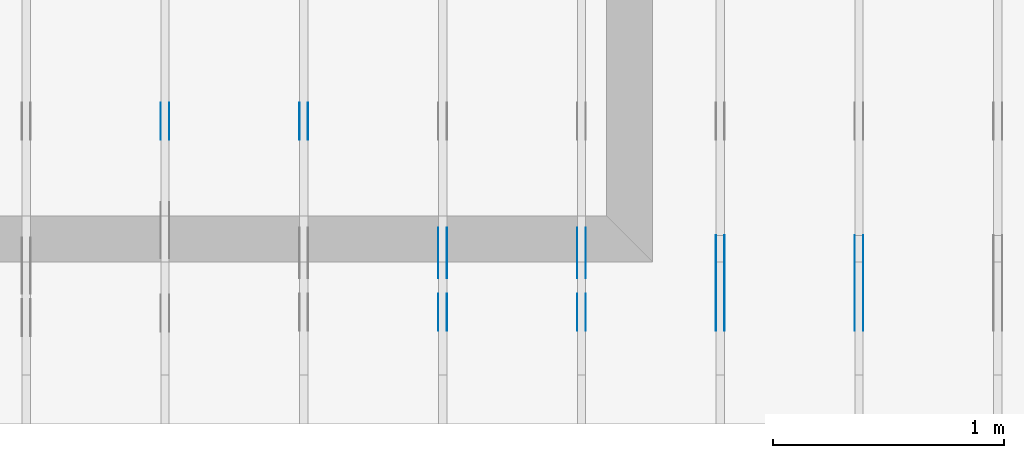
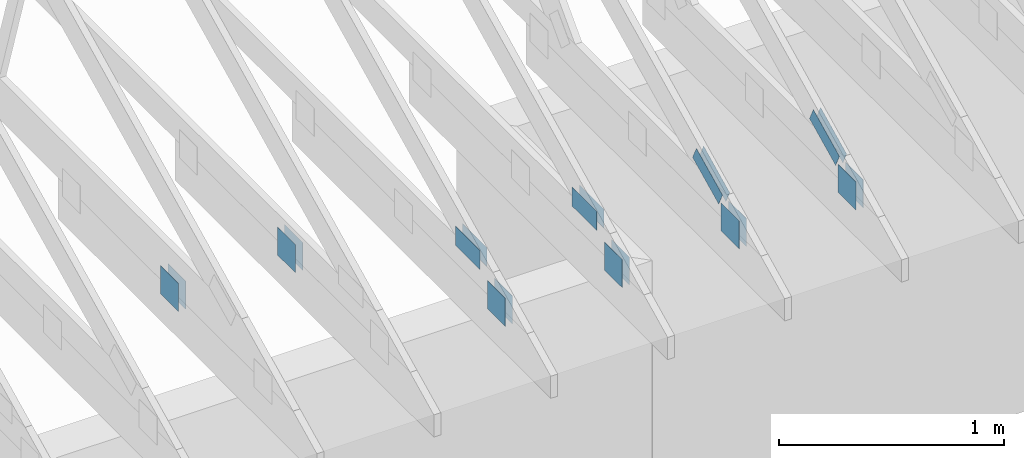
# One storey, part 61 of 159: 20 plates, 6 elements without a shape of their own.
"""IFC2X3 building model written with IfcOpenShell, lengths in millimetres."""

from ifc_helpers import new_model, si_unit, frame, origin, origin_with_axes, origin_2d, place, context, project, spatial, faceted_brep, element, aggregate, save


model = new_model("IFC2X3")

# Units and contexts
model_context = context("Model", 3, precision=1e-05, world=origin())
plan_context = context("Plan", 2, precision=1e-05, world=origin_2d())
ifc_project = project(units=[si_unit("LENGTHUNIT", "METRE", prefix="MILLI"), si_unit("AREAUNIT", "SQUARE_METRE"), si_unit("VOLUMEUNIT", "CUBIC_METRE"), si_unit("SOLIDANGLEUNIT", "STERADIAN"), si_unit("PLANEANGLEUNIT", "RADIAN"), si_unit("MASSUNIT", "GRAM"), si_unit("TIMEUNIT", "SECOND"), si_unit("THERMODYNAMICTEMPERATUREUNIT", "DEGREE_CELSIUS"), si_unit("LUMINOUSINTENSITYUNIT", "LUMEN")], contexts=[model_context, plan_context])

# Site, building, storey
site_placement = place(None, origin_with_axes())
site = spatial("IfcSite", under=ifc_project, at=site_placement, CompositionType="ELEMENT")
building_placement = place(site_placement, origin_with_axes())
building = spatial("IfcBuilding", under=site, at=building_placement, Name="Plan 1", CompositionType="ELEMENT")
storey_placement = place(building_placement, origin_with_axes())
storey = spatial("IfcBuildingStorey", under=building, at=storey_placement, Name="Etasje 1", CompositionType="ELEMENT", Elevation=0.0)

# Assembly, plates
assembly_1_placement = place(storey_placement, frame((7275.0222614047525, 9699.99999999999, 1.1021457184401395e-15), z_axis=(-1.0, 1.836909530733566e-16, 6.123031769111886e-17), x_axis=(-1.836909530733566e-16, -1.0, 0.0)))
assembly_1 = element("IfcElementAssembly", 1, at=assembly_1_placement, inside=storey, Name="T2 (90)", AssemblyPlace="FACTORY", PredefinedType="TRUSS")
plate_1_placement = place(assembly_1_placement, frame((9849.1689453125, 348.6043090820308, 0.0), z_axis=(0.0, 0.0, 1.0), x_axis=(-0.898794046299167, 0.4383711467890773, 0.0)))
plate_1 = element("IfcPlate", 2, at=plate_1_placement, Name="GNT100S 76x258", context=model_context, shape_type="Brep", body=[
    faceted_brep([(257.99999468874375, 76.00008915613216, 1.0), (0.00017802805450628512, 76.00008915613216, 1.0), (0.0, 0.0, 1.0), (258.0006943892513, 0.0, 1.0), (0.00017802805450628512, 76.00008915613216, 2.1801428670703325e-20), (257.99999468874375, 76.00008915613216, 3.1594843278197516e-14), (258.0006943892513, 0.0003658529813037603, 3.159492896396625e-14), (0.0, 0.0003658529813037603, 0.0), (258.0004204757515, 0.0002198311096505291, -1.1564171119434705e-29), (258.0004204757515, 0.00021983110965059034, 1.0), (0.0004204757515253732, 0.00021983110855223245, 1.0), (0.0004204757515253732, 0.00021983110855217122, -1.8055593228630336e-35), (258.0004204757515, 76.00021983110946, 0.0), (258.0004204757515, 76.00021983110946, 1.0), (258.0004204757515, 0.00021983110946166562, 1.0), (258.0004204757515, 0.00021983110946166562, 0.0), (0.0004204757515253732, 76.00021983110855, 0.0), (0.0004204757515253732, 76.00021983110855, 1.0), (258.0004204757515, 76.00021983110945, 1.0), (258.0004204757515, 76.00021983110945, -7.888609052210118e-31), (0.0004204757515253732, 0.00021983110855217092, -3.009265538105056e-36), (0.00042047575152543446, 0.00021983110855217092, 1.0), (0.00042047575153474146, 76.00021983110855, 1.0), (0.0004204757515346802, 76.00021983110855, -5.698736427475688e-31)], [[[0, 1, 2, 3]], [[4, 5, 6, 7]], [[8, 9, 10, 11]], [[12, 13, 14, 15]], [[16, 17, 18, 19]], [[20, 21, 22, 23]]]),
])
plate_2_placement = place(assembly_1_placement, frame((9849.1689453125, 348.6043090820308, -37.0), z_axis=(0.0, 0.0, 1.0), x_axis=(-0.898794046299167, 0.4383711467890773, 0.0)))
plate_2 = element("IfcPlate", 3, at=plate_2_placement, Name="GNT100S 76x258", context=model_context, shape_type="Brep", body=[
    faceted_brep([(257.99999468874375, 76.00008915613216, 1.0), (0.00017802805450628512, 76.00008915613216, 1.0), (0.0, 0.0, 1.0), (258.0006943892513, 0.0, 1.0), (0.00017802805450628512, 76.00008915613216, 2.1801428670703325e-20), (257.99999468874375, 76.00008915613216, 3.1594843278197516e-14), (258.0006943892513, 0.0003658529813037603, 3.159492896396625e-14), (0.0, 0.0003658529813037603, 0.0), (258.0004204757515, 0.0002198311096505291, -1.1564171119434705e-29), (258.0004204757515, 0.00021983110965059034, 1.0), (0.0004204757515253732, 0.00021983110855223245, 1.0), (0.0004204757515253732, 0.00021983110855217122, -1.8055593228630336e-35), (258.0004204757515, 76.00021983110946, 0.0), (258.0004204757515, 76.00021983110946, 1.0), (258.0004204757515, 0.00021983110946166562, 1.0), (258.0004204757515, 0.00021983110946166562, 0.0), (0.0004204757515253732, 76.00021983110855, 0.0), (0.0004204757515253732, 76.00021983110855, 1.0), (258.0004204757515, 76.00021983110945, 1.0), (258.0004204757515, 76.00021983110945, -7.888609052210118e-31), (0.0004204757515253732, 0.00021983110855217092, -3.009265538105056e-36), (0.00042047575152543446, 0.00021983110855217092, 1.0), (0.00042047575153474146, 76.00021983110855, 1.0), (0.0004204757515346802, 76.00021983110855, -5.698736427475688e-31)], [[[0, 1, 2, 3]], [[4, 5, 6, 7]], [[8, 9, 10, 11]], [[12, 13, 14, 15]], [[16, 17, 18, 19]], [[20, 21, 22, 23]]]),
])
plate_3_placement = place(assembly_1_placement, frame((9997.207498348753, 299.0000000000001, 0.0), z_axis=(0.0, 0.0, 1.0), x_axis=(-1.0, 1.2246063538223773e-16, 0.0)))
plate_3 = element("IfcPlate", 4, at=plate_3_placement, Name="GNT100S 152x159", context=model_context, shape_type="Brep", body=[
    faceted_brep([(159.00046709875278, 152.00000000000014, 1.0), (0.0004670987527788384, 152.00000000000014, 1.0), (0.0004670987527788384, 1.1368683772161603e-13, 1.0), (159.00046709875278, 1.1368683772161603e-13, 1.0), (0.0004670987527788384, 152.00000000000014, 5.720121005154733e-20), (159.00046709875278, 152.00000000000014, 1.947129822698585e-14), (159.00046709875278, 1.7053025658242404e-13, 1.947129822698585e-14), (0.0004670987527788384, 1.7053025658242404e-13, 5.720121005154733e-20), (159.0, -2.92068615386637e-14, 5.2688860062695115e-30), (159.0, -2.914563122097258e-14, 1.0), (1.1247455413666031e-32, 6.123031769111886e-17, 1.0), (0.0, 0.0, 0.0), (159.0, 152.00000000000006, 0.0), (159.0, 152.00000000000006, 1.0), (159.0, 5.684341886080802e-14, 1.0), (159.0, 5.684341886080802e-14, 0.0), (0.0, 152.00000000000003, 0.0), (0.0, 152.00000000000003, 1.0), (159.0, 152.00000000000006, 1.0), (159.0, 152.00000000000006, 0.0), (0.0, 0.0, 0.0), (6.123031769111886e-17, -7.498303609110687e-33, 1.0), (1.8675246895791256e-14, 152.00000000000003, 1.0), (1.8614016578100137e-14, 152.00000000000003, -1.1397421485848246e-30)], [[[0, 1, 2, 3]], [[4, 5, 6, 7]], [[8, 9, 10, 11]], [[12, 13, 14, 15]], [[16, 17, 18, 19]], [[20, 21, 22, 23]]]),
])
plate_4_placement = place(assembly_1_placement, frame((9997.207498348753, 299.0000000000001, -37.0), z_axis=(0.0, 0.0, 1.0), x_axis=(-1.0, 1.2246063538223773e-16, 0.0)))
plate_4 = element("IfcPlate", 5, at=plate_4_placement, Name="GNT100S 152x159", context=model_context, shape_type="Brep", body=[
    faceted_brep([(159.00046709875278, 152.00000000000014, 1.0), (0.0004670987527788384, 152.00000000000014, 1.0), (0.0004670987527788384, 1.1368683772161603e-13, 1.0), (159.00046709875278, 1.1368683772161603e-13, 1.0), (0.0004670987527788384, 152.00000000000014, 5.720121005154733e-20), (159.00046709875278, 152.00000000000014, 1.947129822698585e-14), (159.00046709875278, 1.7053025658242404e-13, 1.947129822698585e-14), (0.0004670987527788384, 1.7053025658242404e-13, 5.720121005154733e-20), (159.0, -2.92068615386637e-14, 5.2688860062695115e-30), (159.0, -2.914563122097258e-14, 1.0), (1.1247455413666031e-32, 6.123031769111886e-17, 1.0), (0.0, 0.0, 0.0), (159.0, 152.00000000000006, 0.0), (159.0, 152.00000000000006, 1.0), (159.0, 5.684341886080802e-14, 1.0), (159.0, 5.684341886080802e-14, 0.0), (0.0, 152.00000000000003, 0.0), (0.0, 152.00000000000003, 1.0), (159.0, 152.00000000000006, 1.0), (159.0, 152.00000000000006, 0.0), (0.0, 0.0, 0.0), (6.123031769111886e-17, -7.498303609110687e-33, 1.0), (1.8675246895791256e-14, 152.00000000000003, 1.0), (1.8614016578100137e-14, 152.00000000000003, -1.1397421485848246e-30)], [[[0, 1, 2, 3]], [[4, 5, 6, 7]], [[8, 9, 10, 11]], [[12, 13, 14, 15]], [[16, 17, 18, 19]], [[20, 21, 22, 23]]]),
])
aggregate(assembly_1, [plate_1, plate_2, plate_3, plate_4])

assembly_2_placement = place(storey_placement, frame((6675.0222614047525, 9699.99999999999, 1.1021457184401395e-15), z_axis=(-1.0, 1.836909530733566e-16, 6.123031769111886e-17), x_axis=(-1.836909530733566e-16, -1.0, 0.0)))
assembly_2 = element("IfcElementAssembly", 6, at=assembly_2_placement, inside=storey, Name="T2 (89)", AssemblyPlace="FACTORY", PredefinedType="TRUSS")
plate_5_placement = place(assembly_2_placement, frame((9849.1689453125, 348.6043090820308, 0.0), z_axis=(0.0, 0.0, 1.0), x_axis=(-0.898794046299167, 0.4383711467890773, 0.0)))
plate_5 = element("IfcPlate", 7, at=plate_5_placement, Name="GNT100S 76x258", context=model_context, shape_type="Brep", body=[
    faceted_brep([(257.99999468874375, 76.00008915613216, 1.0), (0.00017802805450628512, 76.00008915613216, 1.0), (0.0, 0.0, 1.0), (258.0006943892513, 0.0, 1.0), (0.00017802805450628512, 76.00008915613216, 2.1801428670703325e-20), (257.99999468874375, 76.00008915613216, 3.1594843278197516e-14), (258.0006943892513, 0.0003658529813037603, 3.159492896396625e-14), (0.0, 0.0003658529813037603, 0.0), (258.0004204757515, 0.0002198311096505291, -1.1564171119434705e-29), (258.0004204757515, 0.00021983110965059034, 1.0), (0.0004204757515253732, 0.00021983110855223245, 1.0), (0.0004204757515253732, 0.00021983110855217122, -1.8055593228630336e-35), (258.0004204757515, 76.00021983110946, 0.0), (258.0004204757515, 76.00021983110946, 1.0), (258.0004204757515, 0.00021983110946166562, 1.0), (258.0004204757515, 0.00021983110946166562, 0.0), (0.0004204757515253732, 76.00021983110855, 0.0), (0.0004204757515253732, 76.00021983110855, 1.0), (258.0004204757515, 76.00021983110945, 1.0), (258.0004204757515, 76.00021983110945, -7.888609052210118e-31), (0.0004204757515253732, 0.00021983110855217092, -3.009265538105056e-36), (0.00042047575152543446, 0.00021983110855217092, 1.0), (0.00042047575153474146, 76.00021983110855, 1.0), (0.0004204757515346802, 76.00021983110855, -5.698736427475688e-31)], [[[0, 1, 2, 3]], [[4, 5, 6, 7]], [[8, 9, 10, 11]], [[12, 13, 14, 15]], [[16, 17, 18, 19]], [[20, 21, 22, 23]]]),
])
plate_6_placement = place(assembly_2_placement, frame((9849.1689453125, 348.6043090820308, -37.0), z_axis=(0.0, 0.0, 1.0), x_axis=(-0.898794046299167, 0.4383711467890773, 0.0)))
plate_6 = element("IfcPlate", 8, at=plate_6_placement, Name="GNT100S 76x258", context=model_context, shape_type="Brep", body=[
    faceted_brep([(257.99999468874375, 76.00008915613216, 1.0), (0.00017802805450628512, 76.00008915613216, 1.0), (0.0, 0.0, 1.0), (258.0006943892513, 0.0, 1.0), (0.00017802805450628512, 76.00008915613216, 2.1801428670703325e-20), (257.99999468874375, 76.00008915613216, 3.1594843278197516e-14), (258.0006943892513, 0.0003658529813037603, 3.159492896396625e-14), (0.0, 0.0003658529813037603, 0.0), (258.0004204757515, 0.0002198311096505291, -1.1564171119434705e-29), (258.0004204757515, 0.00021983110965059034, 1.0), (0.0004204757515253732, 0.00021983110855223245, 1.0), (0.0004204757515253732, 0.00021983110855217122, -1.8055593228630336e-35), (258.0004204757515, 76.00021983110946, 0.0), (258.0004204757515, 76.00021983110946, 1.0), (258.0004204757515, 0.00021983110946166562, 1.0), (258.0004204757515, 0.00021983110946166562, 0.0), (0.0004204757515253732, 76.00021983110855, 0.0), (0.0004204757515253732, 76.00021983110855, 1.0), (258.0004204757515, 76.00021983110945, 1.0), (258.0004204757515, 76.00021983110945, -7.888609052210118e-31), (0.0004204757515253732, 0.00021983110855217092, -3.009265538105056e-36), (0.00042047575152543446, 0.00021983110855217092, 1.0), (0.00042047575153474146, 76.00021983110855, 1.0), (0.0004204757515346802, 76.00021983110855, -5.698736427475688e-31)], [[[0, 1, 2, 3]], [[4, 5, 6, 7]], [[8, 9, 10, 11]], [[12, 13, 14, 15]], [[16, 17, 18, 19]], [[20, 21, 22, 23]]]),
])
plate_7_placement = place(assembly_2_placement, frame((9997.207498348753, 299.0000000000001, 0.0), z_axis=(0.0, 0.0, 1.0), x_axis=(-1.0, 1.2246063538223773e-16, 0.0)))
plate_7 = element("IfcPlate", 9, at=plate_7_placement, Name="GNT100S 152x159", context=model_context, shape_type="Brep", body=[
    faceted_brep([(159.00046709875278, 152.00000000000014, 1.0), (0.0004670987527788384, 152.00000000000014, 1.0), (0.0004670987527788384, 1.1368683772161603e-13, 1.0), (159.00046709875278, 1.1368683772161603e-13, 1.0), (0.0004670987527788384, 152.00000000000014, 5.720121005154733e-20), (159.00046709875278, 152.00000000000014, 1.947129822698585e-14), (159.00046709875278, 1.7053025658242404e-13, 1.947129822698585e-14), (0.0004670987527788384, 1.7053025658242404e-13, 5.720121005154733e-20), (159.0, -2.92068615386637e-14, 5.2688860062695115e-30), (159.0, -2.914563122097258e-14, 1.0), (1.1247455413666031e-32, 6.123031769111886e-17, 1.0), (0.0, 0.0, 0.0), (159.0, 152.00000000000006, 0.0), (159.0, 152.00000000000006, 1.0), (159.0, 5.684341886080802e-14, 1.0), (159.0, 5.684341886080802e-14, 0.0), (0.0, 152.00000000000003, 0.0), (0.0, 152.00000000000003, 1.0), (159.0, 152.00000000000006, 1.0), (159.0, 152.00000000000006, 0.0), (0.0, 0.0, 0.0), (6.123031769111886e-17, -7.498303609110687e-33, 1.0), (1.8675246895791256e-14, 152.00000000000003, 1.0), (1.8614016578100137e-14, 152.00000000000003, -1.1397421485848246e-30)], [[[0, 1, 2, 3]], [[4, 5, 6, 7]], [[8, 9, 10, 11]], [[12, 13, 14, 15]], [[16, 17, 18, 19]], [[20, 21, 22, 23]]]),
])
plate_8_placement = place(assembly_2_placement, frame((9997.207498348753, 299.0000000000001, -37.0), z_axis=(0.0, 0.0, 1.0), x_axis=(-1.0, 1.2246063538223773e-16, 0.0)))
plate_8 = element("IfcPlate", 10, at=plate_8_placement, Name="GNT100S 152x159", context=model_context, shape_type="Brep", body=[
    faceted_brep([(159.00046709875278, 152.00000000000014, 1.0), (0.0004670987527788384, 152.00000000000014, 1.0), (0.0004670987527788384, 1.1368683772161603e-13, 1.0), (159.00046709875278, 1.1368683772161603e-13, 1.0), (0.0004670987527788384, 152.00000000000014, 5.720121005154733e-20), (159.00046709875278, 152.00000000000014, 1.947129822698585e-14), (159.00046709875278, 1.7053025658242404e-13, 1.947129822698585e-14), (0.0004670987527788384, 1.7053025658242404e-13, 5.720121005154733e-20), (159.0, -2.92068615386637e-14, 5.2688860062695115e-30), (159.0, -2.914563122097258e-14, 1.0), (1.1247455413666031e-32, 6.123031769111886e-17, 1.0), (0.0, 0.0, 0.0), (159.0, 152.00000000000006, 0.0), (159.0, 152.00000000000006, 1.0), (159.0, 5.684341886080802e-14, 1.0), (159.0, 5.684341886080802e-14, 0.0), (0.0, 152.00000000000003, 0.0), (0.0, 152.00000000000003, 1.0), (159.0, 152.00000000000006, 1.0), (159.0, 152.00000000000006, 0.0), (0.0, 0.0, 0.0), (6.123031769111886e-17, -7.498303609110687e-33, 1.0), (1.8675246895791256e-14, 152.00000000000003, 1.0), (1.8614016578100137e-14, 152.00000000000003, -1.1397421485848246e-30)], [[[0, 1, 2, 3]], [[4, 5, 6, 7]], [[8, 9, 10, 11]], [[12, 13, 14, 15]], [[16, 17, 18, 19]], [[20, 21, 22, 23]]]),
])
aggregate(assembly_2, [plate_5, plate_6, plate_7, plate_8])

assembly_3_placement = place(storey_placement, frame((5475.0222614047525, 9699.99999999999, 1.1021457184401395e-15), z_axis=(-1.0, 1.836909530733566e-16, 6.123031769111886e-17), x_axis=(-1.836909530733566e-16, -1.0, 0.0)))
assembly_3 = element("IfcElementAssembly", 11, at=assembly_3_placement, inside=storey, Name="T1 (87)", AssemblyPlace="FACTORY", PredefinedType="TRUSS")
plate_9_placement = place(assembly_3_placement, frame((9771.373046875, 422.5, 0.0), z_axis=(0.0, 0.0, 1.0), x_axis=(-1.0, 1.2246063538223773e-16, 0.0)))
plate_9 = element("IfcPlate", 12, at=plate_9_placement, Name="GNT100S 103x218", context=model_context, shape_type="Brep", body=[
    faceted_brep([(218.0, 103.0, 1.0), (0.0, 103.0, 1.0), (0.0, 0.0, 1.0), (218.0, 0.0, 1.0), (0.0, 103.0, 0.0), (218.0, 103.0, 2.6696418513327824e-14), (218.0, 0.0, 2.6696418513327824e-14), (0.0, 0.0, 0.0), (218.00038098239747, 6.989197474374928e-13, 2.4519495652617233e-30), (218.00038098239747, 6.989809777551839e-13, 1.0), (0.0003809823974734172, 7.390256055251756e-13, 1.0), (0.0003809823974734172, 7.389643752074845e-13, 4.2850825286007214e-36), (218.00038098239747, 103.00000000000074, 0.0), (218.00038098239747, 103.00000000000074, 1.0), (218.00038098239747, 7.389644451905042e-13, 1.0), (218.00038098239747, 7.389644451905042e-13, 0.0), (0.0003809823974734172, 103.00000000000074, 0.0), (0.0003809823974734172, 103.00000000000074, 1.0), (218.00038098239747, 103.00000000000072, 1.0), (218.00038098239747, 103.00000000000072, -7.888609052210118e-31), (0.0003809823974734172, 7.389644451905042e-13, 0.0), (0.0003809823974734785, 7.389644451905042e-13, 1.0), (0.0003809823974860919, 103.00000000000074, 1.0), (0.00038098239748603067, 103.00000000000074, -7.723249910891245e-31)], [[[0, 1, 2, 3]], [[4, 5, 6, 7]], [[8, 9, 10, 11]], [[12, 13, 14, 15]], [[16, 17, 18, 19]], [[20, 21, 22, 23]]]),
])
plate_10_placement = place(assembly_3_placement, frame((9771.373046875, 422.5, -37.0), z_axis=(0.0, 0.0, 1.0), x_axis=(-1.0, 1.2246063538223773e-16, 0.0)))
plate_10 = element("IfcPlate", 13, at=plate_10_placement, Name="GNT100S 103x218", context=model_context, shape_type="Brep", body=[
    faceted_brep([(218.0, 103.0, 1.0), (0.0, 103.0, 1.0), (0.0, 0.0, 1.0), (218.0, 0.0, 1.0), (0.0, 103.0, 0.0), (218.0, 103.0, 2.6696418513327824e-14), (218.0, 0.0, 2.6696418513327824e-14), (0.0, 0.0, 0.0), (218.00038098239747, 6.989197474374928e-13, 2.4519495652617233e-30), (218.00038098239747, 6.989809777551839e-13, 1.0), (0.0003809823974734172, 7.390256055251756e-13, 1.0), (0.0003809823974734172, 7.389643752074845e-13, 4.2850825286007214e-36), (218.00038098239747, 103.00000000000074, 0.0), (218.00038098239747, 103.00000000000074, 1.0), (218.00038098239747, 7.389644451905042e-13, 1.0), (218.00038098239747, 7.389644451905042e-13, 0.0), (0.0003809823974734172, 103.00000000000074, 0.0), (0.0003809823974734172, 103.00000000000074, 1.0), (218.00038098239747, 103.00000000000072, 1.0), (218.00038098239747, 103.00000000000072, -7.888609052210118e-31), (0.0003809823974734172, 7.389644451905042e-13, 0.0), (0.0003809823974734785, 7.389644451905042e-13, 1.0), (0.0003809823974860919, 103.00000000000074, 1.0), (0.00038098239748603067, 103.00000000000074, -7.723249910891245e-31)], [[[0, 1, 2, 3]], [[4, 5, 6, 7]], [[8, 9, 10, 11]], [[12, 13, 14, 15]], [[16, 17, 18, 19]], [[20, 21, 22, 23]]]),
])
plate_11_placement = place(assembly_3_placement, frame((9997.207498348753, 299.0000000000001, 0.0), z_axis=(0.0, 0.0, 1.0), x_axis=(-1.0, 1.2246063538223773e-16, 0.0)))
plate_11 = element("IfcPlate", 14, at=plate_11_placement, Name="GNT100S 152x159", context=model_context, shape_type="Brep", body=[
    faceted_brep([(159.00046709875278, 152.00000000000014, 1.0), (0.0004670987527788384, 152.00000000000014, 1.0), (0.0004670987527788384, 1.1368683772161603e-13, 1.0), (159.00046709875278, 1.1368683772161603e-13, 1.0), (0.0004670987527788384, 152.00000000000014, 5.720121005154733e-20), (159.00046709875278, 152.00000000000014, 1.947129822698585e-14), (159.00046709875278, 1.7053025658242404e-13, 1.947129822698585e-14), (0.0004670987527788384, 1.7053025658242404e-13, 5.720121005154733e-20), (159.0, -2.92068615386637e-14, 5.2688860062695115e-30), (159.0, -2.914563122097258e-14, 1.0), (1.1247455413666031e-32, 6.123031769111886e-17, 1.0), (0.0, 0.0, 0.0), (159.0, 152.00000000000006, 0.0), (159.0, 152.00000000000006, 1.0), (159.0, 5.684341886080802e-14, 1.0), (159.0, 5.684341886080802e-14, 0.0), (0.0, 152.00000000000003, 0.0), (0.0, 152.00000000000003, 1.0), (159.0, 152.00000000000006, 1.0), (159.0, 152.00000000000006, 0.0), (0.0, 0.0, 0.0), (6.123031769111886e-17, -7.498303609110687e-33, 1.0), (1.8675246895791256e-14, 152.00000000000003, 1.0), (1.8614016578100137e-14, 152.00000000000003, -1.1397421485848246e-30)], [[[0, 1, 2, 3]], [[4, 5, 6, 7]], [[8, 9, 10, 11]], [[12, 13, 14, 15]], [[16, 17, 18, 19]], [[20, 21, 22, 23]]]),
])
plate_12_placement = place(assembly_3_placement, frame((9997.207498348753, 299.0000000000001, -37.0), z_axis=(0.0, 0.0, 1.0), x_axis=(-1.0, 1.2246063538223773e-16, 0.0)))
plate_12 = element("IfcPlate", 15, at=plate_12_placement, Name="GNT100S 152x159", context=model_context, shape_type="Brep", body=[
    faceted_brep([(159.00046709875278, 152.00000000000014, 1.0), (0.0004670987527788384, 152.00000000000014, 1.0), (0.0004670987527788384, 1.1368683772161603e-13, 1.0), (159.00046709875278, 1.1368683772161603e-13, 1.0), (0.0004670987527788384, 152.00000000000014, 5.720121005154733e-20), (159.00046709875278, 152.00000000000014, 1.947129822698585e-14), (159.00046709875278, 1.7053025658242404e-13, 1.947129822698585e-14), (0.0004670987527788384, 1.7053025658242404e-13, 5.720121005154733e-20), (159.0, -2.92068615386637e-14, 5.2688860062695115e-30), (159.0, -2.914563122097258e-14, 1.0), (1.1247455413666031e-32, 6.123031769111886e-17, 1.0), (0.0, 0.0, 0.0), (159.0, 152.00000000000006, 0.0), (159.0, 152.00000000000006, 1.0), (159.0, 5.684341886080802e-14, 1.0), (159.0, 5.684341886080802e-14, 0.0), (0.0, 152.00000000000003, 0.0), (0.0, 152.00000000000003, 1.0), (159.0, 152.00000000000006, 1.0), (159.0, 152.00000000000006, 0.0), (0.0, 0.0, 0.0), (6.123031769111886e-17, -7.498303609110687e-33, 1.0), (1.8675246895791256e-14, 152.00000000000003, 1.0), (1.8614016578100137e-14, 152.00000000000003, -1.1397421485848246e-30)], [[[0, 1, 2, 3]], [[4, 5, 6, 7]], [[8, 9, 10, 11]], [[12, 13, 14, 15]], [[16, 17, 18, 19]], [[20, 21, 22, 23]]]),
])
aggregate(assembly_3, [plate_9, plate_10, plate_11, plate_12])

assembly_4_placement = place(storey_placement, frame((4875.0222614047525, 9699.99999999999, 1.1021457184401395e-15), z_axis=(-1.0, 1.836909530733566e-16, 6.123031769111886e-17), x_axis=(-1.836909530733566e-16, -1.0, 0.0)))
assembly_4 = element("IfcElementAssembly", 16, at=assembly_4_placement, inside=storey, Name="T1 (86)", AssemblyPlace="FACTORY", PredefinedType="TRUSS")
plate_13_placement = place(assembly_4_placement, frame((9172.147647832993, 299.0, 0.0), z_axis=(0.0, 0.0, 1.0), x_axis=(-1.0, 1.2246063538223773e-16, 0.0)))
plate_13 = element("IfcPlate", 17, at=plate_13_placement, Name="GNT100S 152x159", context=model_context, shape_type="Brep", body=[
    faceted_brep([(159.00018689549324, 152.0, 1.0), (0.0001868954932433553, 152.0, 1.0), (0.0001868954932433553, 0.0, 1.0), (159.00018689549324, 0.0, 1.0), (0.0001868954932433553, 152.0, 2.2887340852658008e-20), (159.00018689549324, 152.0, 1.947126391311665e-14), (159.00018689549324, 5.684341886080802e-14, 1.947126391311665e-14), (0.0001868954932433553, 5.684341886080802e-14, 2.2887340852658008e-20), (159.0, 1.4487220288423447e-12, 5.2688860062695115e-30), (159.0, 1.4487832591600358e-12, 1.0), (1.1247455413666031e-32, 1.4779901206986995e-12, 1.0), (0.0, 1.4779288903810084e-12, 0.0), (159.0, 152.0000000000015, 0.0), (159.0, 152.0000000000015, 1.0), (159.0, 1.5347723092418164e-12, 1.0), (159.0, 1.5347723092418164e-12, 0.0), (0.0, 152.00000000000148, 0.0), (0.0, 152.00000000000148, 1.0), (159.0, 152.0000000000015, 1.0), (159.0, 152.0000000000015, 0.0), (1.8098811096582386e-28, 1.4779288903810084e-12, -1.1081959532752868e-44), (6.123031769129986e-17, 1.4779288903810084e-12, 1.0), (1.8675246895791433e-14, 152.00000000000148, 1.0), (1.8614016578100314e-14, 152.00000000000148, -1.1397421485848355e-30)], [[[0, 1, 2, 3]], [[4, 5, 6, 7]], [[8, 9, 10, 11]], [[12, 13, 14, 15]], [[16, 17, 18, 19]], [[20, 21, 22, 23]]]),
])
plate_14_placement = place(assembly_4_placement, frame((9172.147647832993, 299.0, -37.0), z_axis=(0.0, 0.0, 1.0), x_axis=(-1.0, 1.2246063538223773e-16, 0.0)))
plate_14 = element("IfcPlate", 18, at=plate_14_placement, Name="GNT100S 152x159", context=model_context, shape_type="Brep", body=[
    faceted_brep([(159.00018689549324, 152.0, 1.0), (0.0001868954932433553, 152.0, 1.0), (0.0001868954932433553, 0.0, 1.0), (159.00018689549324, 0.0, 1.0), (0.0001868954932433553, 152.0, 2.2887340852658008e-20), (159.00018689549324, 152.0, 1.947126391311665e-14), (159.00018689549324, 5.684341886080802e-14, 1.947126391311665e-14), (0.0001868954932433553, 5.684341886080802e-14, 2.2887340852658008e-20), (159.0, 1.4487220288423447e-12, 5.2688860062695115e-30), (159.0, 1.4487832591600358e-12, 1.0), (1.1247455413666031e-32, 1.4779901206986995e-12, 1.0), (0.0, 1.4779288903810084e-12, 0.0), (159.0, 152.0000000000015, 0.0), (159.0, 152.0000000000015, 1.0), (159.0, 1.5347723092418164e-12, 1.0), (159.0, 1.5347723092418164e-12, 0.0), (0.0, 152.00000000000148, 0.0), (0.0, 152.00000000000148, 1.0), (159.0, 152.0000000000015, 1.0), (159.0, 152.0000000000015, 0.0), (1.8098811096582386e-28, 1.4779288903810084e-12, -1.1081959532752868e-44), (6.123031769129986e-17, 1.4779288903810084e-12, 1.0), (1.8675246895791433e-14, 152.00000000000148, 1.0), (1.8614016578100314e-14, 152.00000000000148, -1.1397421485848355e-30)], [[[0, 1, 2, 3]], [[4, 5, 6, 7]], [[8, 9, 10, 11]], [[12, 13, 14, 15]], [[16, 17, 18, 19]], [[20, 21, 22, 23]]]),
])
aggregate(assembly_4, [plate_13, plate_14])

assembly_5_placement = place(storey_placement, frame((6075.0222614047525, 9699.99999999999, 1.1021457184401395e-15), z_axis=(-1.0, 1.836909530733566e-16, 6.123031769111886e-17), x_axis=(-1.836909530733566e-16, -1.0, 0.0)))
assembly_5 = element("IfcElementAssembly", 19, at=assembly_5_placement, inside=storey, Name="T1 (88)", AssemblyPlace="FACTORY", PredefinedType="TRUSS")
plate_15_placement = place(assembly_5_placement, frame((9771.373046875, 422.5, 0.0), z_axis=(0.0, 0.0, 1.0), x_axis=(-1.0, 1.2246063538223773e-16, 0.0)))
plate_15 = element("IfcPlate", 20, at=plate_15_placement, Name="GNT100S 103x218", context=model_context, shape_type="Brep", body=[
    faceted_brep([(218.0, 103.0, 1.0), (0.0, 103.0, 1.0), (0.0, 0.0, 1.0), (218.0, 0.0, 1.0), (0.0, 103.0, 0.0), (218.0, 103.0, 2.6696418513327824e-14), (218.0, 0.0, 2.6696418513327824e-14), (0.0, 0.0, 0.0), (218.00038098239747, 6.989197474374928e-13, 2.4519495652617233e-30), (218.00038098239747, 6.989809777551839e-13, 1.0), (0.0003809823974734172, 7.390256055251756e-13, 1.0), (0.0003809823974734172, 7.389643752074845e-13, 4.2850825286007214e-36), (218.00038098239747, 103.00000000000074, 0.0), (218.00038098239747, 103.00000000000074, 1.0), (218.00038098239747, 7.389644451905042e-13, 1.0), (218.00038098239747, 7.389644451905042e-13, 0.0), (0.0003809823974734172, 103.00000000000074, 0.0), (0.0003809823974734172, 103.00000000000074, 1.0), (218.00038098239747, 103.00000000000072, 1.0), (218.00038098239747, 103.00000000000072, -7.888609052210118e-31), (0.0003809823974734172, 7.389644451905042e-13, 0.0), (0.0003809823974734785, 7.389644451905042e-13, 1.0), (0.0003809823974860919, 103.00000000000074, 1.0), (0.00038098239748603067, 103.00000000000074, -7.723249910891245e-31)], [[[0, 1, 2, 3]], [[4, 5, 6, 7]], [[8, 9, 10, 11]], [[12, 13, 14, 15]], [[16, 17, 18, 19]], [[20, 21, 22, 23]]]),
])
plate_16_placement = place(assembly_5_placement, frame((9771.373046875, 422.5, -37.0), z_axis=(0.0, 0.0, 1.0), x_axis=(-1.0, 1.2246063538223773e-16, 0.0)))
plate_16 = element("IfcPlate", 21, at=plate_16_placement, Name="GNT100S 103x218", context=model_context, shape_type="Brep", body=[
    faceted_brep([(218.0, 103.0, 1.0), (0.0, 103.0, 1.0), (0.0, 0.0, 1.0), (218.0, 0.0, 1.0), (0.0, 103.0, 0.0), (218.0, 103.0, 2.6696418513327824e-14), (218.0, 0.0, 2.6696418513327824e-14), (0.0, 0.0, 0.0), (218.00038098239747, 6.989197474374928e-13, 2.4519495652617233e-30), (218.00038098239747, 6.989809777551839e-13, 1.0), (0.0003809823974734172, 7.390256055251756e-13, 1.0), (0.0003809823974734172, 7.389643752074845e-13, 4.2850825286007214e-36), (218.00038098239747, 103.00000000000074, 0.0), (218.00038098239747, 103.00000000000074, 1.0), (218.00038098239747, 7.389644451905042e-13, 1.0), (218.00038098239747, 7.389644451905042e-13, 0.0), (0.0003809823974734172, 103.00000000000074, 0.0), (0.0003809823974734172, 103.00000000000074, 1.0), (218.00038098239747, 103.00000000000072, 1.0), (218.00038098239747, 103.00000000000072, -7.888609052210118e-31), (0.0003809823974734172, 7.389644451905042e-13, 0.0), (0.0003809823974734785, 7.389644451905042e-13, 1.0), (0.0003809823974860919, 103.00000000000074, 1.0), (0.00038098239748603067, 103.00000000000074, -7.723249910891245e-31)], [[[0, 1, 2, 3]], [[4, 5, 6, 7]], [[8, 9, 10, 11]], [[12, 13, 14, 15]], [[16, 17, 18, 19]], [[20, 21, 22, 23]]]),
])
plate_17_placement = place(assembly_5_placement, frame((9997.207498348753, 299.0000000000001, 0.0), z_axis=(0.0, 0.0, 1.0), x_axis=(-1.0, 1.2246063538223773e-16, 0.0)))
plate_17 = element("IfcPlate", 22, at=plate_17_placement, Name="GNT100S 152x159", context=model_context, shape_type="Brep", body=[
    faceted_brep([(159.00046709875278, 152.00000000000014, 1.0), (0.0004670987527788384, 152.00000000000014, 1.0), (0.0004670987527788384, 1.1368683772161603e-13, 1.0), (159.00046709875278, 1.1368683772161603e-13, 1.0), (0.0004670987527788384, 152.00000000000014, 5.720121005154733e-20), (159.00046709875278, 152.00000000000014, 1.947129822698585e-14), (159.00046709875278, 1.7053025658242404e-13, 1.947129822698585e-14), (0.0004670987527788384, 1.7053025658242404e-13, 5.720121005154733e-20), (159.0, -2.92068615386637e-14, 5.2688860062695115e-30), (159.0, -2.914563122097258e-14, 1.0), (1.1247455413666031e-32, 6.123031769111886e-17, 1.0), (0.0, 0.0, 0.0), (159.0, 152.00000000000006, 0.0), (159.0, 152.00000000000006, 1.0), (159.0, 5.684341886080802e-14, 1.0), (159.0, 5.684341886080802e-14, 0.0), (0.0, 152.00000000000003, 0.0), (0.0, 152.00000000000003, 1.0), (159.0, 152.00000000000006, 1.0), (159.0, 152.00000000000006, 0.0), (0.0, 0.0, 0.0), (6.123031769111886e-17, -7.498303609110687e-33, 1.0), (1.8675246895791256e-14, 152.00000000000003, 1.0), (1.8614016578100137e-14, 152.00000000000003, -1.1397421485848246e-30)], [[[0, 1, 2, 3]], [[4, 5, 6, 7]], [[8, 9, 10, 11]], [[12, 13, 14, 15]], [[16, 17, 18, 19]], [[20, 21, 22, 23]]]),
])
plate_18_placement = place(assembly_5_placement, frame((9997.207498348753, 299.0000000000001, -37.0), z_axis=(0.0, 0.0, 1.0), x_axis=(-1.0, 1.2246063538223773e-16, 0.0)))
plate_18 = element("IfcPlate", 23, at=plate_18_placement, Name="GNT100S 152x159", context=model_context, shape_type="Brep", body=[
    faceted_brep([(159.00046709875278, 152.00000000000014, 1.0), (0.0004670987527788384, 152.00000000000014, 1.0), (0.0004670987527788384, 1.1368683772161603e-13, 1.0), (159.00046709875278, 1.1368683772161603e-13, 1.0), (0.0004670987527788384, 152.00000000000014, 5.720121005154733e-20), (159.00046709875278, 152.00000000000014, 1.947129822698585e-14), (159.00046709875278, 1.7053025658242404e-13, 1.947129822698585e-14), (0.0004670987527788384, 1.7053025658242404e-13, 5.720121005154733e-20), (159.0, -2.92068615386637e-14, 5.2688860062695115e-30), (159.0, -2.914563122097258e-14, 1.0), (1.1247455413666031e-32, 6.123031769111886e-17, 1.0), (0.0, 0.0, 0.0), (159.0, 152.00000000000006, 0.0), (159.0, 152.00000000000006, 1.0), (159.0, 5.684341886080802e-14, 1.0), (159.0, 5.684341886080802e-14, 0.0), (0.0, 152.00000000000003, 0.0), (0.0, 152.00000000000003, 1.0), (159.0, 152.00000000000006, 1.0), (159.0, 152.00000000000006, 0.0), (0.0, 0.0, 0.0), (6.123031769111886e-17, -7.498303609110687e-33, 1.0), (1.8675246895791256e-14, 152.00000000000003, 1.0), (1.8614016578100137e-14, 152.00000000000003, -1.1397421485848246e-30)], [[[0, 1, 2, 3]], [[4, 5, 6, 7]], [[8, 9, 10, 11]], [[12, 13, 14, 15]], [[16, 17, 18, 19]], [[20, 21, 22, 23]]]),
])
aggregate(assembly_5, [plate_15, plate_16, plate_17, plate_18])

assembly_6_placement = place(storey_placement, frame((4275.022261406632, 9700.000260373617, 1.1021457184401395e-15), z_axis=(-0.999999999895379, 1.4465201327097478e-05, 6.123031769111886e-17), x_axis=(-1.4465201327097478e-05, -0.999999999895379, 0.0)))
assembly_6 = element("IfcElementAssembly", 24, at=assembly_6_placement, inside=storey, Name="V13 (6)", AssemblyPlace="FACTORY", PredefinedType="TRUSS")
plate_19_placement = place(assembly_6_placement, frame((9172.147648902665, 299.0, 0.0), z_axis=(0.0, 0.0, 1.0), x_axis=(-1.0, 1.2246063538223773e-16, 0.0)))
plate_19 = element("IfcPlate", 25, at=plate_19_placement, Name="GNT100S 152x159", context=model_context, shape_type="Brep", body=[
    faceted_brep([(159.0001879651645, 152.0, 1.0), (0.00018796516451402567, 152.0, 1.0), (0.00018796516451402567, 0.0, 1.0), (159.0001879651645, 0.0, 1.0), (0.00018796516451402567, 152.0, 2.3018333476114427e-20), (159.0001879651645, 152.0, 1.9471264044109275e-14), (159.0001879651645, 5.684341886080802e-14, 1.9471264044109275e-14), (0.00018796516451402567, 5.684341886080802e-14, 2.3018333476114427e-20), (159.0, 1.4487220288423447e-12, 5.2688860062695115e-30), (159.0, 1.4487832591600358e-12, 1.0), (1.1247455413666031e-32, 1.4779901206986995e-12, 1.0), (0.0, 1.4779288903810084e-12, 0.0), (159.0, 152.0000000000015, 0.0), (159.0, 152.0000000000015, 1.0), (159.0, 1.5347723092418164e-12, 1.0), (159.0, 1.5347723092418164e-12, 0.0), (0.0, 152.00000000000148, 0.0), (0.0, 152.00000000000148, 1.0), (159.0, 152.0000000000015, 1.0), (159.0, 152.0000000000015, 0.0), (1.8098811096582386e-28, 1.4779288903810084e-12, -1.1081959532752868e-44), (6.123031769129986e-17, 1.4779288903810084e-12, 1.0), (1.8675246895791433e-14, 152.00000000000148, 1.0), (1.8614016578100314e-14, 152.00000000000148, -1.1397421485848355e-30)], [[[0, 1, 2, 3]], [[4, 5, 6, 7]], [[8, 9, 10, 11]], [[12, 13, 14, 15]], [[16, 17, 18, 19]], [[20, 21, 22, 23]]]),
])
plate_20_placement = place(assembly_6_placement, frame((9172.147648902665, 299.0, -37.0), z_axis=(0.0, 0.0, 1.0), x_axis=(-1.0, 1.2246063538223773e-16, 0.0)))
plate_20 = element("IfcPlate", 26, at=plate_20_placement, Name="GNT100S 152x159", context=model_context, shape_type="Brep", body=[
    faceted_brep([(159.0001879651645, 152.0, 1.0), (0.00018796516451402567, 152.0, 1.0), (0.00018796516451402567, 0.0, 1.0), (159.0001879651645, 0.0, 1.0), (0.00018796516451402567, 152.0, 2.3018333476114427e-20), (159.0001879651645, 152.0, 1.9471264044109275e-14), (159.0001879651645, 5.684341886080802e-14, 1.9471264044109275e-14), (0.00018796516451402567, 5.684341886080802e-14, 2.3018333476114427e-20), (159.0, 1.4487220288423447e-12, 5.2688860062695115e-30), (159.0, 1.4487832591600358e-12, 1.0), (1.1247455413666031e-32, 1.4779901206986995e-12, 1.0), (0.0, 1.4779288903810084e-12, 0.0), (159.0, 152.0000000000015, 0.0), (159.0, 152.0000000000015, 1.0), (159.0, 1.5347723092418164e-12, 1.0), (159.0, 1.5347723092418164e-12, 0.0), (0.0, 152.00000000000148, 0.0), (0.0, 152.00000000000148, 1.0), (159.0, 152.0000000000015, 1.0), (159.0, 152.0000000000015, 0.0), (1.8098811096582386e-28, 1.4779288903810084e-12, -1.1081959532752868e-44), (6.123031769129986e-17, 1.4779288903810084e-12, 1.0), (1.8675246895791433e-14, 152.00000000000148, 1.0), (1.8614016578100314e-14, 152.00000000000148, -1.1397421485848355e-30)], [[[0, 1, 2, 3]], [[4, 5, 6, 7]], [[8, 9, 10, 11]], [[12, 13, 14, 15]], [[16, 17, 18, 19]], [[20, 21, 22, 23]]]),
])
aggregate(assembly_6, [plate_19, plate_20])

save(model, "model.ifc")
